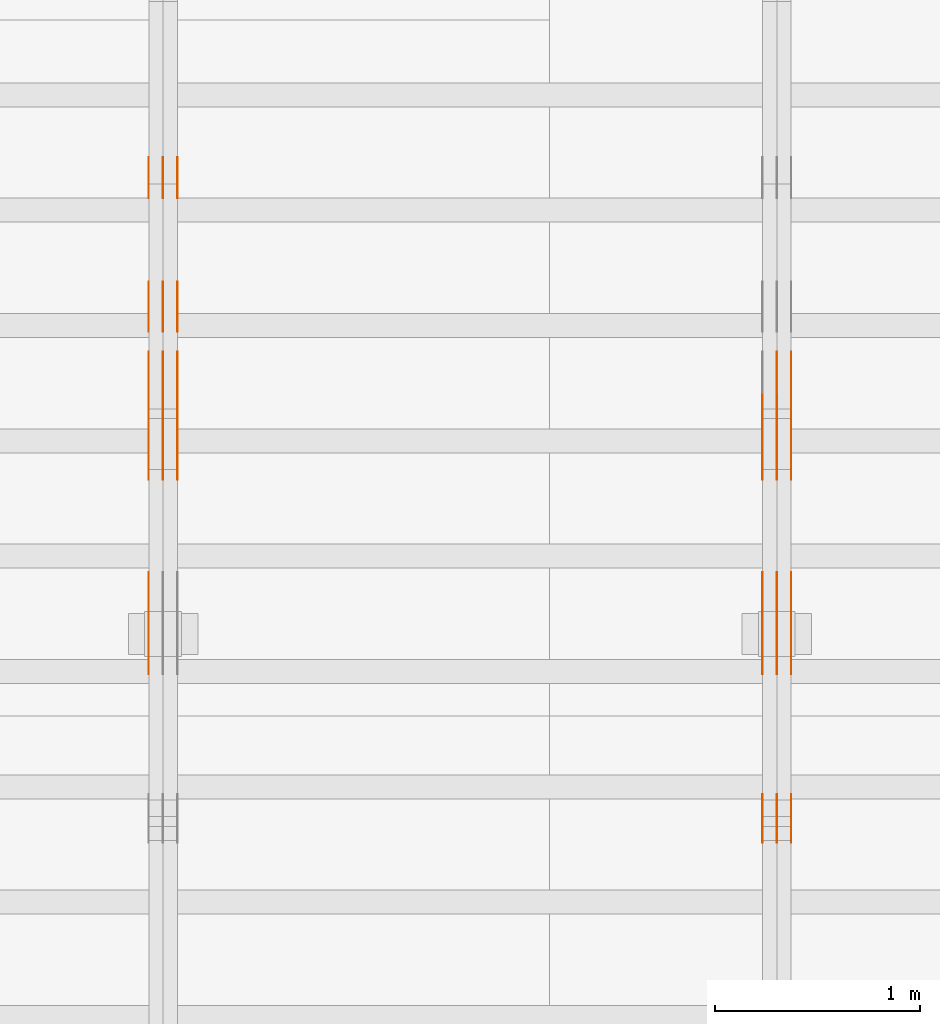
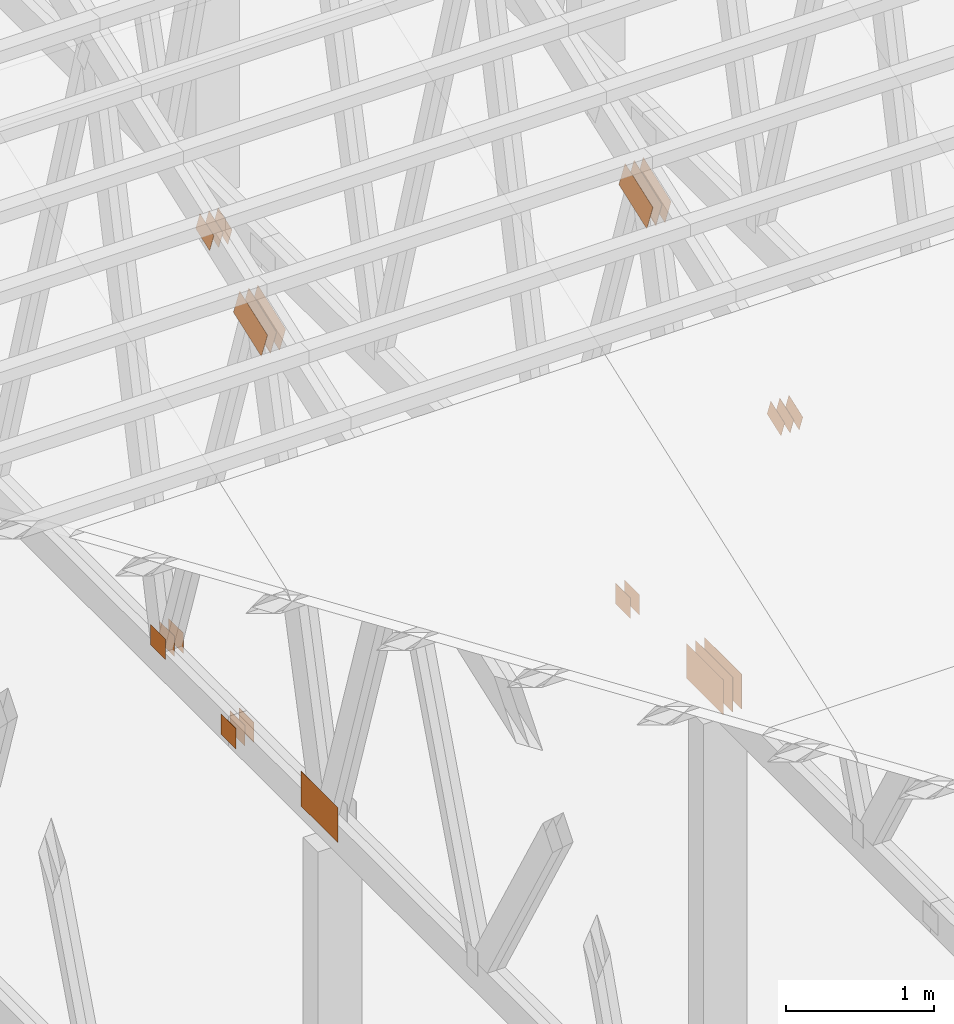
# One storey, part 77 of 189: 31 proxies.
"""IFC2X3 building model written with IfcOpenShell, lengths in millimetres."""

from ifc_helpers import new_model, entity, si_unit, converted_unit, derived_unit, direction, frame, frame_2d, origin, origin_2d_with_axis, place, context, subcontext, project, spatial, polyline, rectangle, outline, extrude, source, transform, mapped, material, type_object, type_shapes, element, save


model = new_model("IFC2X3")

# Units and contexts
model_context = context("Model", 3, precision=0.01, world=origin(), true_north=direction((6.12303176911189e-17, 1.0)))
body_context = subcontext(model_context, "Body", "Model", "MODEL_VIEW")
ifc_project = project(units=[si_unit("LENGTHUNIT", "METRE", prefix="MILLI"), si_unit("AREAUNIT", "SQUARE_METRE"), si_unit("VOLUMEUNIT", "CUBIC_METRE"), converted_unit("PLANEANGLEUNIT", "DEGREE", entity("IfcRatioMeasure", 0.0174532925199433), si_unit("PLANEANGLEUNIT", "RADIAN"), dimensions=[0, 0, 0, 0, 0, 0, 0]), si_unit("MASSUNIT", "GRAM", prefix="KILO"), derived_unit("MASSDENSITYUNIT", [(si_unit("MASSUNIT", "GRAM", prefix="KILO"), 1), (si_unit("LENGTHUNIT", "METRE"), -3)]), si_unit("TIMEUNIT", "SECOND"), si_unit("FREQUENCYUNIT", "HERTZ"), si_unit("THERMODYNAMICTEMPERATUREUNIT", "DEGREE_CELSIUS"), derived_unit("THERMALTRANSMITTANCEUNIT", [(si_unit("MASSUNIT", "GRAM", prefix="KILO"), 1), (si_unit("THERMODYNAMICTEMPERATUREUNIT", "KELVIN"), -1), (si_unit("TIMEUNIT", "SECOND"), -3)]), derived_unit("VOLUMETRICFLOWRATEUNIT", [(si_unit("LENGTHUNIT", "METRE"), 3), (si_unit("TIMEUNIT", "SECOND"), -1)]), si_unit("ELECTRICCURRENTUNIT", "AMPERE"), si_unit("ELECTRICVOLTAGEUNIT", "VOLT"), si_unit("POWERUNIT", "WATT"), si_unit("FORCEUNIT", "NEWTON"), si_unit("ILLUMINANCEUNIT", "LUX"), si_unit("LUMINOUSFLUXUNIT", "LUMEN"), si_unit("LUMINOUSINTENSITYUNIT", "CANDELA"), derived_unit("USERDEFINED", [(si_unit("MASSUNIT", "GRAM", prefix="KILO"), -1), (si_unit("LENGTHUNIT", "METRE"), -2), (si_unit("TIMEUNIT", "SECOND"), 3), (si_unit("LUMINOUSFLUXUNIT", "LUMEN"), 1)]), derived_unit("LINEARVELOCITYUNIT", [(si_unit("LENGTHUNIT", "METRE"), 1), (si_unit("TIMEUNIT", "SECOND"), -1)]), si_unit("PRESSUREUNIT", "PASCAL"), derived_unit("USERDEFINED", [(si_unit("LENGTHUNIT", "METRE"), -2), (si_unit("MASSUNIT", "GRAM", prefix="KILO"), 1), (si_unit("TIMEUNIT", "SECOND"), -2)])], contexts=[model_context])

# Site, building, storey
site_placement = place(None, origin())
site = spatial("IfcSite", under=ifc_project, at=site_placement, CompositionType="ELEMENT")
building_placement = place(site_placement, origin())
building = spatial("IfcBuilding", under=site, at=building_placement, CompositionType="ELEMENT")
storey_placement = place(building_placement, origin())
storey = spatial("IfcBuildingStorey", under=building, at=storey_placement, Name="Default", CompositionType="ELEMENT", Elevation=0.0)

# Proxies
ifc_material_1 = material(Name="IfcSurfaceStyle #45142")
building_element_proxy_type_1 = type_object("IfcBuildingElementProxyType", PredefinedType="NOTDEFINED", material=ifc_material_1)
shared_shape_1 = source(origin(), body_context, "Body", "SweptSolid", [
    extrude(outline(polyline([(-199.999582244654, -119.99984375717), (200.000344770932, -119.99984375717), (199.999582244655, 119.99984375717), (-200.000344770934, 119.99984375717), (-199.999582244654, -119.99984375717)])), frame((200.000344770932, 120.0000091947, 0.0), z_axis=(0.0, 0.0, 1.0), x_axis=(-1.0, 0.0, 0.0)), (0.0, 0.0, 1.0), 1.29999999999999),
])
type_shapes(building_element_proxy_type_1, [shared_shape_1])
proxy_1_placement = place(building_placement, frame((6336.3, 9961.90704972973, 3612.2451494258), z_axis=(-1.0, 0.0, 0.0), x_axis=(0.0, -0.939692620785908, -0.342020143325669)))
element("IfcBuildingElementProxy", 1, at=proxy_1_placement, inside=storey, type_object=building_element_proxy_type_1, material=ifc_material_1, context=body_context, shape_type="MappedRepresentation", body=[
    mapped(shared_shape_1, transform((0.0, 0.0, 0.0), scale=1.0)),
])
ifc_material_2 = material(Name="IfcSurfaceStyle #45085")
building_element_proxy_type_2 = type_object("IfcBuildingElementProxyType", PredefinedType="NOTDEFINED", material=ifc_material_2)
shared_shape_2 = source(origin(), body_context, "Body", "SweptSolid", [
    extrude(outline(polyline([(-199.999582244654, -119.99984375717), (200.000344770932, -119.99984375717), (199.999582244655, 119.99984375717), (-200.000344770934, 119.99984375717), (-199.999582244654, -119.99984375717)])), frame((200.000344770932, 120.0000091947, 0.0), z_axis=(0.0, 0.0, 1.0), x_axis=(-1.0, 0.0, 0.0)), (0.0, 0.0, 1.0), 1.29999999999997),
])
type_shapes(building_element_proxy_type_2, [shared_shape_2])
proxy_2_placement = place(building_placement, frame((6265.0, 9961.90704972973, 3612.2451494258), z_axis=(-1.0, 0.0, 0.0), x_axis=(0.0, -0.939692620785908, -0.342020143325669)))
element("IfcBuildingElementProxy", 2, at=proxy_2_placement, inside=storey, type_object=building_element_proxy_type_2, material=ifc_material_2, context=body_context, shape_type="MappedRepresentation", body=[
    mapped(shared_shape_2, transform((0.0, 0.0, 0.0), scale=1.0)),
])
ifc_material_3 = material(Name="IfcSurfaceStyle #45028")
building_element_proxy_type_3 = type_object("IfcBuildingElementProxyType", PredefinedType="NOTDEFINED", material=ifc_material_3)
shared_shape_3 = source(origin(), body_context, "Body", "SweptSolid", [
    extrude(outline(polyline([(-199.999582244654, -119.99984375717), (200.000344770932, -119.99984375717), (199.999582244655, 119.99984375717), (-200.000344770934, 119.99984375717), (-199.999582244654, -119.99984375717)])), frame((200.000344770932, 120.0000091947, 0.0), z_axis=(0.0, 0.0, 1.0), x_axis=(-1.0, 0.0, 0.0)), (0.0, 0.0, 1.0), 1.29999999999997),
])
type_shapes(building_element_proxy_type_3, [shared_shape_3])
proxy_3_placement = place(building_placement, frame((6266.3, 9961.90704972973, 3612.2451494258), z_axis=(-1.0, 0.0, 0.0), x_axis=(0.0, -0.939692620785908, -0.342020143325669)))
element("IfcBuildingElementProxy", 3, at=proxy_3_placement, inside=storey, type_object=building_element_proxy_type_3, material=ifc_material_3, context=body_context, shape_type="MappedRepresentation", body=[
    mapped(shared_shape_3, transform((0.0, 0.0, 0.0), scale=1.0)),
])
ifc_material_4 = material(Name="IfcSurfaceStyle #44971")
building_element_proxy_type_4 = type_object("IfcBuildingElementProxyType", PredefinedType="NOTDEFINED", material=ifc_material_4)
shared_shape_4 = source(origin(), body_context, "Body", "SweptSolid", [
    extrude(outline(polyline([(-199.999582244654, -119.99984375717), (200.000344770932, -119.99984375717), (199.999582244655, 119.99984375717), (-200.000344770934, 119.99984375717), (-199.999582244654, -119.99984375717)])), frame((200.000344770932, 120.0000091947, 0.0), z_axis=(0.0, 0.0, 1.0), x_axis=(-1.0, 0.0, 0.0)), (0.0, 0.0, 1.0), 1.29999999999998),
])
type_shapes(building_element_proxy_type_4, [shared_shape_4])
proxy_4_placement = place(building_placement, frame((6195.0, 9961.90704972973, 3612.2451494258), z_axis=(-1.0, 0.0, 0.0), x_axis=(0.0, -0.939692620785908, -0.342020143325669)))
element("IfcBuildingElementProxy", 4, at=proxy_4_placement, inside=storey, type_object=building_element_proxy_type_4, material=ifc_material_4, context=body_context, shape_type="MappedRepresentation", body=[
    mapped(shared_shape_4, transform((0.0, 0.0, 0.0), scale=1.0)),
])
ifc_material_5 = material(Name="IfcSurfaceStyle #44458")
building_element_proxy_type_5 = type_object("IfcBuildingElementProxyType", PredefinedType="NOTDEFINED", material=ifc_material_5)
shared_shape_5 = source(origin(), body_context, "Body", "SweptSolid", [
    extrude(rectangle(XDim=500.0, YDim=288.0, at=frame_2d((0.0, 1.4210854715202e-14), x_axis=(1.0, 0.0))), frame((250.000973740011, 144.0, 0.0), z_axis=(0.0, 0.0, 1.0), x_axis=(-1.0, 0.0, 0.0)), (0.0, 0.0, 1.0), 1.29999999999998),
])
type_shapes(building_element_proxy_type_5, [shared_shape_5])
proxy_5_placement = place(building_placement, frame((6336.3, 8551.90918250999, 389.0), z_axis=(-1.0, 0.0, 0.0), x_axis=(0.0, 1.0, 0.0)))
element("IfcBuildingElementProxy", 5, at=proxy_5_placement, inside=storey, type_object=building_element_proxy_type_5, material=ifc_material_5, context=body_context, shape_type="MappedRepresentation", body=[
    mapped(shared_shape_5, transform((0.0, 0.0, 0.0), scale=1.0)),
])
ifc_material_6 = material(Name="IfcSurfaceStyle #44401")
building_element_proxy_type_6 = type_object("IfcBuildingElementProxyType", PredefinedType="NOTDEFINED", material=ifc_material_6)
shared_shape_6 = source(origin(), body_context, "Body", "SweptSolid", [
    extrude(rectangle(XDim=500.0, YDim=288.0, at=frame_2d((0.0, 1.4210854715202e-14), x_axis=(1.0, 0.0))), frame((250.000973740011, 144.0, 0.0), z_axis=(0.0, 0.0, 1.0), x_axis=(-1.0, 0.0, 0.0)), (0.0, 0.0, 1.0), 1.29999999999997),
])
type_shapes(building_element_proxy_type_6, [shared_shape_6])
proxy_6_placement = place(building_placement, frame((6265.0, 8551.90918250999, 389.0), z_axis=(-1.0, 0.0, 0.0), x_axis=(0.0, 1.0, 0.0)))
element("IfcBuildingElementProxy", 6, at=proxy_6_placement, inside=storey, type_object=building_element_proxy_type_6, material=ifc_material_6, context=body_context, shape_type="MappedRepresentation", body=[
    mapped(shared_shape_6, transform((0.0, 0.0, 0.0), scale=1.0)),
])
ifc_material_7 = material(Name="IfcSurfaceStyle #44344")
building_element_proxy_type_7 = type_object("IfcBuildingElementProxyType", PredefinedType="NOTDEFINED", material=ifc_material_7)
shared_shape_7 = source(origin(), body_context, "Body", "SweptSolid", [
    extrude(rectangle(XDim=500.0, YDim=288.0, at=frame_2d((0.0, 1.4210854715202e-14), x_axis=(1.0, 0.0))), frame((250.000973740011, 144.0, 0.0), z_axis=(0.0, 0.0, 1.0), x_axis=(-1.0, 0.0, 0.0)), (0.0, 0.0, 1.0), 1.29999999999997),
])
type_shapes(building_element_proxy_type_7, [shared_shape_7])
proxy_7_placement = place(building_placement, frame((6266.3, 8551.90918250999, 389.0), z_axis=(-1.0, 0.0, 0.0), x_axis=(0.0, 1.0, 0.0)))
element("IfcBuildingElementProxy", 7, at=proxy_7_placement, inside=storey, type_object=building_element_proxy_type_7, material=ifc_material_7, context=body_context, shape_type="MappedRepresentation", body=[
    mapped(shared_shape_7, transform((0.0, 0.0, 0.0), scale=1.0)),
])
ifc_material_8 = material(Name="IfcSurfaceStyle #44287")
building_element_proxy_type_8 = type_object("IfcBuildingElementProxyType", PredefinedType="NOTDEFINED", material=ifc_material_8)
shared_shape_8 = source(origin(), body_context, "Body", "SweptSolid", [
    extrude(rectangle(XDim=500.0, YDim=288.0, at=frame_2d((0.0, 1.4210854715202e-14), x_axis=(1.0, 0.0))), frame((250.000973740011, 144.0, 0.0), z_axis=(0.0, 0.0, 1.0), x_axis=(-1.0, 0.0, 0.0)), (0.0, 0.0, 1.0), 1.29999999999997),
])
type_shapes(building_element_proxy_type_8, [shared_shape_8])
proxy_8_placement = place(building_placement, frame((6195.0, 8551.90918250999, 389.0), z_axis=(-1.0, 0.0, 0.0), x_axis=(0.0, 1.0, 0.0)))
element("IfcBuildingElementProxy", 8, at=proxy_8_placement, inside=storey, type_object=building_element_proxy_type_8, material=ifc_material_8, context=body_context, shape_type="MappedRepresentation", body=[
    mapped(shared_shape_8, transform((0.0, 0.0, 0.0), scale=1.0)),
])
ifc_material_9 = material(Name="IfcSurfaceStyle #44230")
building_element_proxy_type_9 = type_object("IfcBuildingElementProxyType", PredefinedType="NOTDEFINED", material=ifc_material_9)
shared_shape_9 = source(origin(), body_context, "Body", "SweptSolid", [
    extrude(outline(polyline([(-100.00048713087, -72.0000025659129), (100.000394045495, -72.0000025659129), (99.9995694622958, 72.0000025659129), (-99.9994763769209, 72.0000025659128), (-100.00048713087, -72.0000025659129)])), frame((100.000394045495, 72.0000025659128, 0.0), z_axis=(0.0, 0.0, 1.0), x_axis=(-1.0, 0.0, 0.0)), (0.0, 0.0, 1.0), 1.3),
])
type_shapes(building_element_proxy_type_9, [shared_shape_9])
proxy_9_placement = place(building_placement, frame((6336.3, 7965.16887114408, 2936.19963864386), z_axis=(-1.0, 0.0, 0.0), x_axis=(0.0, -0.939692620785908, -0.342020143325669)))
element("IfcBuildingElementProxy", 9, at=proxy_9_placement, inside=storey, type_object=building_element_proxy_type_9, material=ifc_material_9, context=body_context, shape_type="MappedRepresentation", body=[
    mapped(shared_shape_9, transform((0.0, 0.0, 0.0), scale=1.0)),
])
ifc_material_10 = material(Name="IfcSurfaceStyle #44173")
building_element_proxy_type_10 = type_object("IfcBuildingElementProxyType", PredefinedType="NOTDEFINED", material=ifc_material_10)
shared_shape_10 = source(origin(), body_context, "Body", "SweptSolid", [
    extrude(outline(polyline([(-100.00048713087, -72.0000025659129), (100.000394045495, -72.0000025659129), (99.9995694622958, 72.0000025659129), (-99.9994763769209, 72.0000025659128), (-100.00048713087, -72.0000025659129)])), frame((100.000394045495, 72.0000025659128, 0.0), z_axis=(0.0, 0.0, 1.0), x_axis=(-1.0, 0.0, 0.0)), (0.0, 0.0, 1.0), 1.29999999999998),
])
type_shapes(building_element_proxy_type_10, [shared_shape_10])
proxy_10_placement = place(building_placement, frame((6265.0, 7965.16887114408, 2936.19963864386), z_axis=(-1.0, 0.0, 0.0), x_axis=(0.0, -0.939692620785908, -0.342020143325669)))
element("IfcBuildingElementProxy", 10, at=proxy_10_placement, inside=storey, type_object=building_element_proxy_type_10, material=ifc_material_10, context=body_context, shape_type="MappedRepresentation", body=[
    mapped(shared_shape_10, transform((0.0, 0.0, 0.0), scale=1.0)),
])
ifc_material_11 = material(Name="IfcSurfaceStyle #44116")
building_element_proxy_type_11 = type_object("IfcBuildingElementProxyType", PredefinedType="NOTDEFINED", material=ifc_material_11)
shared_shape_11 = source(origin(), body_context, "Body", "SweptSolid", [
    extrude(outline(polyline([(-100.00048713087, -72.0000025659129), (100.000394045495, -72.0000025659129), (99.9995694622958, 72.0000025659129), (-99.9994763769209, 72.0000025659128), (-100.00048713087, -72.0000025659129)])), frame((100.000394045495, 72.0000025659128, 0.0), z_axis=(0.0, 0.0, 1.0), x_axis=(-1.0, 0.0, 0.0)), (0.0, 0.0, 1.0), 1.29999999999998),
])
type_shapes(building_element_proxy_type_11, [shared_shape_11])
proxy_11_placement = place(building_placement, frame((6266.3, 7965.16887114408, 2936.19963864386), z_axis=(-1.0, 0.0, 0.0), x_axis=(0.0, -0.939692620785908, -0.342020143325669)))
element("IfcBuildingElementProxy", 11, at=proxy_11_placement, inside=storey, type_object=building_element_proxy_type_11, material=ifc_material_11, context=body_context, shape_type="MappedRepresentation", body=[
    mapped(shared_shape_11, transform((0.0, 0.0, 0.0), scale=1.0)),
])
ifc_material_12 = material(Name="IfcSurfaceStyle #44059")
building_element_proxy_type_12 = type_object("IfcBuildingElementProxyType", PredefinedType="NOTDEFINED", material=ifc_material_12)
shared_shape_12 = source(origin(), body_context, "Body", "SweptSolid", [
    extrude(outline(polyline([(-100.00048713087, -72.0000025659129), (100.000394045495, -72.0000025659129), (99.9995694622958, 72.0000025659129), (-99.9994763769209, 72.0000025659128), (-100.00048713087, -72.0000025659129)])), frame((100.000394045495, 72.0000025659128, 0.0), z_axis=(0.0, 0.0, 1.0), x_axis=(-1.0, 0.0, 0.0)), (0.0, 0.0, 1.0), 1.29999999999999),
])
type_shapes(building_element_proxy_type_12, [shared_shape_12])
proxy_12_placement = place(building_placement, frame((6195.0, 7965.16887114408, 2936.19963864386), z_axis=(-1.0, 0.0, 0.0), x_axis=(0.0, -0.939692620785908, -0.342020143325669)))
element("IfcBuildingElementProxy", 12, at=proxy_12_placement, inside=storey, type_object=building_element_proxy_type_12, material=ifc_material_12, context=body_context, shape_type="MappedRepresentation", body=[
    mapped(shared_shape_12, transform((0.0, 0.0, 0.0), scale=1.0)),
])
ifc_material_13 = material(Name="IfcSurfaceStyle #38818")
building_element_proxy_type_13 = type_object("IfcBuildingElementProxyType", PredefinedType="NOTDEFINED", material=ifc_material_13)
shared_shape_13 = source(origin(), body_context, "Body", "SweptSolid", [
    extrude(rectangle(XDim=200.0, YDim=168.0, at=origin_2d_with_axis()), frame((100.0, 84.0, 0.0), z_axis=(0.0, 0.0, 1.0), x_axis=(-1.0, 0.0, 0.0)), (0.0, 0.0, 1.0), 1.3),
])
type_shapes(building_element_proxy_type_13, [shared_shape_13])
proxy_13_placement = place(building_placement, frame((6336.3, 9929.23046875, 206.5), z_axis=(-1.0, 0.0, 0.0), x_axis=(0.0, 1.0, 0.0)))
element("IfcBuildingElementProxy", 13, at=proxy_13_placement, inside=storey, type_object=building_element_proxy_type_13, material=ifc_material_13, context=body_context, shape_type="MappedRepresentation", body=[
    mapped(shared_shape_13, transform((0.0, 0.0, 0.0), scale=1.0)),
])
ifc_material_14 = material(Name="IfcSurfaceStyle #38761")
building_element_proxy_type_14 = type_object("IfcBuildingElementProxyType", PredefinedType="NOTDEFINED", material=ifc_material_14)
shared_shape_14 = source(origin(), body_context, "Body", "SweptSolid", [
    extrude(rectangle(XDim=200.0, YDim=168.0, at=origin_2d_with_axis()), frame((100.0, 84.0, 0.0), z_axis=(0.0, 0.0, 1.0), x_axis=(-1.0, 0.0, 0.0)), (0.0, 0.0, 1.0), 1.29999999999998),
])
type_shapes(building_element_proxy_type_14, [shared_shape_14])
proxy_14_placement = place(building_placement, frame((6265.0, 9929.23046875, 206.5), z_axis=(-1.0, 0.0, 0.0), x_axis=(0.0, 1.0, 0.0)))
element("IfcBuildingElementProxy", 14, at=proxy_14_placement, inside=storey, type_object=building_element_proxy_type_14, material=ifc_material_14, context=body_context, shape_type="MappedRepresentation", body=[
    mapped(shared_shape_14, transform((0.0, 0.0, 0.0), scale=1.0)),
])
ifc_material_15 = material(Name="IfcSurfaceStyle #29580")
building_element_proxy_type_15 = type_object("IfcBuildingElementProxyType", PredefinedType="NOTDEFINED", material=ifc_material_15)
shared_shape_15 = source(origin(), body_context, "Body", "SweptSolid", [
    extrude(rectangle(XDim=200.0, YDim=168.0, at=origin_2d_with_axis()), frame((100.000765376775, 84.0, 0.0), z_axis=(0.0, 0.0, 1.0), x_axis=(-1.0, 0.0, 0.0)), (0.0, 0.0, 1.0), 1.3),
])
type_shapes(building_element_proxy_type_15, [shared_shape_15])
proxy_15_placement = place(building_placement, frame((3336.3, 10880.1574377482, 365.0), z_axis=(-1.0, 0.0, 0.0), x_axis=(0.0, 1.0, 0.0)))
element("IfcBuildingElementProxy", 15, at=proxy_15_placement, inside=storey, type_object=building_element_proxy_type_15, material=ifc_material_15, context=body_context, shape_type="MappedRepresentation", body=[
    mapped(shared_shape_15, transform((0.0, 0.0, 0.0), scale=1.0)),
])
ifc_material_16 = material(Name="IfcSurfaceStyle #29523")
building_element_proxy_type_16 = type_object("IfcBuildingElementProxyType", PredefinedType="NOTDEFINED", material=ifc_material_16)
shared_shape_16 = source(origin(), body_context, "Body", "SweptSolid", [
    extrude(rectangle(XDim=200.0, YDim=168.0, at=origin_2d_with_axis()), frame((100.000765376775, 84.0, 0.0), z_axis=(0.0, 0.0, 1.0), x_axis=(-1.0, 0.0, 0.0)), (0.0, 0.0, 1.0), 1.29999999999998),
])
type_shapes(building_element_proxy_type_16, [shared_shape_16])
proxy_16_placement = place(building_placement, frame((3265.0, 10880.1574377482, 365.0), z_axis=(-1.0, 0.0, 0.0), x_axis=(0.0, 1.0, 0.0)))
element("IfcBuildingElementProxy", 16, at=proxy_16_placement, inside=storey, type_object=building_element_proxy_type_16, material=ifc_material_16, context=body_context, shape_type="MappedRepresentation", body=[
    mapped(shared_shape_16, transform((0.0, 0.0, 0.0), scale=1.0)),
])
ifc_material_17 = material(Name="IfcSurfaceStyle #29466")
building_element_proxy_type_17 = type_object("IfcBuildingElementProxyType", PredefinedType="NOTDEFINED", material=ifc_material_17)
shared_shape_17 = source(origin(), body_context, "Body", "SweptSolid", [
    extrude(rectangle(XDim=200.0, YDim=168.0, at=origin_2d_with_axis()), frame((100.000765376775, 84.0, 0.0), z_axis=(0.0, 0.0, 1.0), x_axis=(-1.0, 0.0, 0.0)), (0.0, 0.0, 1.0), 1.29999999999998),
])
type_shapes(building_element_proxy_type_17, [shared_shape_17])
proxy_17_placement = place(building_placement, frame((3266.3, 10880.1574377482, 365.0), z_axis=(-1.0, 0.0, 0.0), x_axis=(0.0, 1.0, 0.0)))
element("IfcBuildingElementProxy", 17, at=proxy_17_placement, inside=storey, type_object=building_element_proxy_type_17, material=ifc_material_17, context=body_context, shape_type="MappedRepresentation", body=[
    mapped(shared_shape_17, transform((0.0, 0.0, 0.0), scale=1.0)),
])
ifc_material_18 = material(Name="IfcSurfaceStyle #29409")
building_element_proxy_type_18 = type_object("IfcBuildingElementProxyType", PredefinedType="NOTDEFINED", material=ifc_material_18)
shared_shape_18 = source(origin(), body_context, "Body", "SweptSolid", [
    extrude(rectangle(XDim=200.0, YDim=168.0, at=origin_2d_with_axis()), frame((100.000765376775, 84.0, 0.0), z_axis=(0.0, 0.0, 1.0), x_axis=(-1.0, 0.0, 0.0)), (0.0, 0.0, 1.0), 1.29999999999999),
])
type_shapes(building_element_proxy_type_18, [shared_shape_18])
proxy_18_placement = place(building_placement, frame((3195.0, 10880.1574377482, 365.0), z_axis=(-1.0, 0.0, 0.0), x_axis=(0.0, 1.0, 0.0)))
element("IfcBuildingElementProxy", 18, at=proxy_18_placement, inside=storey, type_object=building_element_proxy_type_18, material=ifc_material_18, context=body_context, shape_type="MappedRepresentation", body=[
    mapped(shared_shape_18, transform((0.0, 0.0, 0.0), scale=1.0)),
])
ifc_material_19 = material(Name="IfcSurfaceStyle #29352")
building_element_proxy_type_19 = type_object("IfcBuildingElementProxyType", PredefinedType="NOTDEFINED", material=ifc_material_19)
shared_shape_19 = source(origin(), body_context, "Body", "SweptSolid", [
    extrude(outline(polyline([(-199.999582244654, -119.99984375717), (200.000344770932, -119.99984375717), (199.999582244655, 119.99984375717), (-200.000344770934, 119.99984375717), (-199.999582244654, -119.99984375717)])), frame((200.000344770932, 120.0000091947, 0.0), z_axis=(0.0, 0.0, 1.0), x_axis=(-1.0, 0.0, 0.0)), (0.0, 0.0, 1.0), 1.29999999999999),
])
type_shapes(building_element_proxy_type_19, [shared_shape_19])
proxy_19_placement = place(building_placement, frame((3336.3, 9961.90704972973, 3612.2451494258), z_axis=(-1.0, 0.0, 0.0), x_axis=(0.0, -0.939692620785908, -0.342020143325669)))
element("IfcBuildingElementProxy", 19, at=proxy_19_placement, inside=storey, type_object=building_element_proxy_type_19, material=ifc_material_19, context=body_context, shape_type="MappedRepresentation", body=[
    mapped(shared_shape_19, transform((0.0, 0.0, 0.0), scale=1.0)),
])
ifc_material_20 = material(Name="IfcSurfaceStyle #29295")
building_element_proxy_type_20 = type_object("IfcBuildingElementProxyType", PredefinedType="NOTDEFINED", material=ifc_material_20)
shared_shape_20 = source(origin(), body_context, "Body", "SweptSolid", [
    extrude(outline(polyline([(-199.999582244654, -119.99984375717), (200.000344770932, -119.99984375717), (199.999582244655, 119.99984375717), (-200.000344770934, 119.99984375717), (-199.999582244654, -119.99984375717)])), frame((200.000344770932, 120.0000091947, 0.0), z_axis=(0.0, 0.0, 1.0), x_axis=(-1.0, 0.0, 0.0)), (0.0, 0.0, 1.0), 1.29999999999997),
])
type_shapes(building_element_proxy_type_20, [shared_shape_20])
proxy_20_placement = place(building_placement, frame((3265.0, 9961.90704972973, 3612.2451494258), z_axis=(-1.0, 0.0, 0.0), x_axis=(0.0, -0.939692620785908, -0.342020143325669)))
element("IfcBuildingElementProxy", 20, at=proxy_20_placement, inside=storey, type_object=building_element_proxy_type_20, material=ifc_material_20, context=body_context, shape_type="MappedRepresentation", body=[
    mapped(shared_shape_20, transform((0.0, 0.0, 0.0), scale=1.0)),
])
ifc_material_21 = material(Name="IfcSurfaceStyle #29238")
building_element_proxy_type_21 = type_object("IfcBuildingElementProxyType", PredefinedType="NOTDEFINED", material=ifc_material_21)
shared_shape_21 = source(origin(), body_context, "Body", "SweptSolid", [
    extrude(outline(polyline([(-199.999582244654, -119.99984375717), (200.000344770932, -119.99984375717), (199.999582244655, 119.99984375717), (-200.000344770934, 119.99984375717), (-199.999582244654, -119.99984375717)])), frame((200.000344770932, 120.0000091947, 0.0), z_axis=(0.0, 0.0, 1.0), x_axis=(-1.0, 0.0, 0.0)), (0.0, 0.0, 1.0), 1.29999999999997),
])
type_shapes(building_element_proxy_type_21, [shared_shape_21])
proxy_21_placement = place(building_placement, frame((3266.3, 9961.90704972973, 3612.2451494258), z_axis=(-1.0, 0.0, 0.0), x_axis=(0.0, -0.939692620785908, -0.342020143325669)))
element("IfcBuildingElementProxy", 21, at=proxy_21_placement, inside=storey, type_object=building_element_proxy_type_21, material=ifc_material_21, context=body_context, shape_type="MappedRepresentation", body=[
    mapped(shared_shape_21, transform((0.0, 0.0, 0.0), scale=1.0)),
])
ifc_material_22 = material(Name="IfcSurfaceStyle #29181")
building_element_proxy_type_22 = type_object("IfcBuildingElementProxyType", PredefinedType="NOTDEFINED", material=ifc_material_22)
shared_shape_22 = source(origin(), body_context, "Body", "SweptSolid", [
    extrude(outline(polyline([(-199.999582244654, -119.99984375717), (200.000344770932, -119.99984375717), (199.999582244655, 119.99984375717), (-200.000344770934, 119.99984375717), (-199.999582244654, -119.99984375717)])), frame((200.000344770932, 120.0000091947, 0.0), z_axis=(0.0, 0.0, 1.0), x_axis=(-1.0, 0.0, 0.0)), (0.0, 0.0, 1.0), 1.29999999999998),
])
type_shapes(building_element_proxy_type_22, [shared_shape_22])
proxy_22_placement = place(building_placement, frame((3195.0, 9961.90704972973, 3612.2451494258), z_axis=(-1.0, 0.0, 0.0), x_axis=(0.0, -0.939692620785908, -0.342020143325669)))
element("IfcBuildingElementProxy", 22, at=proxy_22_placement, inside=storey, type_object=building_element_proxy_type_22, material=ifc_material_22, context=body_context, shape_type="MappedRepresentation", body=[
    mapped(shared_shape_22, transform((0.0, 0.0, 0.0), scale=1.0)),
])
ifc_material_23 = material(Name="IfcSurfaceStyle #28497")
building_element_proxy_type_23 = type_object("IfcBuildingElementProxyType", PredefinedType="NOTDEFINED", material=ifc_material_23)
shared_shape_23 = source(origin(), body_context, "Body", "SweptSolid", [
    extrude(rectangle(XDim=500.0, YDim=288.0, at=frame_2d((0.0, 1.4210854715202e-14), x_axis=(1.0, 0.0))), frame((250.000973740011, 144.0, 0.0), z_axis=(0.0, 0.0, 1.0), x_axis=(-1.0, 0.0, 0.0)), (0.0, 0.0, 1.0), 1.29999999999997),
])
type_shapes(building_element_proxy_type_23, [shared_shape_23])
proxy_23_placement = place(building_placement, frame((3195.0, 8551.90918250999, 389.0), z_axis=(-1.0, 0.0, 0.0), x_axis=(0.0, 1.0, 0.0)))
element("IfcBuildingElementProxy", 23, at=proxy_23_placement, inside=storey, type_object=building_element_proxy_type_23, material=ifc_material_23, context=body_context, shape_type="MappedRepresentation", body=[
    mapped(shared_shape_23, transform((0.0, 0.0, 0.0), scale=1.0)),
])
ifc_material_24 = material(Name="IfcSurfaceStyle #23028")
building_element_proxy_type_24 = type_object("IfcBuildingElementProxyType", PredefinedType="NOTDEFINED", material=ifc_material_24)
shared_shape_24 = source(origin(), body_context, "Body", "SweptSolid", [
    extrude(rectangle(XDim=200.0, YDim=168.0, at=origin_2d_with_axis()), frame((100.0, 84.0, 0.0), z_axis=(0.0, 0.0, 1.0), x_axis=(-1.0, 0.0, 0.0)), (0.0, 0.0, 1.0), 1.3),
])
type_shapes(building_element_proxy_type_24, [shared_shape_24])
proxy_24_placement = place(building_placement, frame((3336.3, 9929.23046875, 206.5), z_axis=(-1.0, 0.0, 0.0), x_axis=(0.0, 1.0, 0.0)))
element("IfcBuildingElementProxy", 24, at=proxy_24_placement, inside=storey, type_object=building_element_proxy_type_24, material=ifc_material_24, context=body_context, shape_type="MappedRepresentation", body=[
    mapped(shared_shape_24, transform((0.0, 0.0, 0.0), scale=1.0)),
])
ifc_material_25 = material(Name="IfcSurfaceStyle #22971")
building_element_proxy_type_25 = type_object("IfcBuildingElementProxyType", PredefinedType="NOTDEFINED", material=ifc_material_25)
shared_shape_25 = source(origin(), body_context, "Body", "SweptSolid", [
    extrude(rectangle(XDim=200.0, YDim=168.0, at=origin_2d_with_axis()), frame((100.0, 84.0, 0.0), z_axis=(0.0, 0.0, 1.0), x_axis=(-1.0, 0.0, 0.0)), (0.0, 0.0, 1.0), 1.29999999999998),
])
type_shapes(building_element_proxy_type_25, [shared_shape_25])
proxy_25_placement = place(building_placement, frame((3265.0, 9929.23046875, 206.5), z_axis=(-1.0, 0.0, 0.0), x_axis=(0.0, 1.0, 0.0)))
element("IfcBuildingElementProxy", 25, at=proxy_25_placement, inside=storey, type_object=building_element_proxy_type_25, material=ifc_material_25, context=body_context, shape_type="MappedRepresentation", body=[
    mapped(shared_shape_25, transform((0.0, 0.0, 0.0), scale=1.0)),
])
ifc_material_26 = material(Name="IfcSurfaceStyle #22914")
building_element_proxy_type_26 = type_object("IfcBuildingElementProxyType", PredefinedType="NOTDEFINED", material=ifc_material_26)
shared_shape_26 = source(origin(), body_context, "Body", "SweptSolid", [
    extrude(rectangle(XDim=200.0, YDim=168.0, at=origin_2d_with_axis()), frame((100.0, 84.0, 0.0), z_axis=(0.0, 0.0, 1.0), x_axis=(-1.0, 0.0, 0.0)), (0.0, 0.0, 1.0), 1.29999999999998),
])
type_shapes(building_element_proxy_type_26, [shared_shape_26])
proxy_26_placement = place(building_placement, frame((3266.3, 9929.23046875, 206.5), z_axis=(-1.0, 0.0, 0.0), x_axis=(0.0, 1.0, 0.0)))
element("IfcBuildingElementProxy", 26, at=proxy_26_placement, inside=storey, type_object=building_element_proxy_type_26, material=ifc_material_26, context=body_context, shape_type="MappedRepresentation", body=[
    mapped(shared_shape_26, transform((0.0, 0.0, 0.0), scale=1.0)),
])
ifc_material_27 = material(Name="IfcSurfaceStyle #22857")
building_element_proxy_type_27 = type_object("IfcBuildingElementProxyType", PredefinedType="NOTDEFINED", material=ifc_material_27)
shared_shape_27 = source(origin(), body_context, "Body", "SweptSolid", [
    extrude(rectangle(XDim=200.0, YDim=168.0, at=origin_2d_with_axis()), frame((100.0, 84.0, 0.0), z_axis=(0.0, 0.0, 1.0), x_axis=(-1.0, 0.0, 0.0)), (0.0, 0.0, 1.0), 1.29999999999999),
])
type_shapes(building_element_proxy_type_27, [shared_shape_27])
proxy_27_placement = place(building_placement, frame((3195.0, 9929.23046875, 206.5), z_axis=(-1.0, 0.0, 0.0), x_axis=(0.0, 1.0, 0.0)))
element("IfcBuildingElementProxy", 27, at=proxy_27_placement, inside=storey, type_object=building_element_proxy_type_27, material=ifc_material_27, context=body_context, shape_type="MappedRepresentation", body=[
    mapped(shared_shape_27, transform((0.0, 0.0, 0.0), scale=1.0)),
])
ifc_material_28 = material(Name="IfcSurfaceStyle #21948")
building_element_proxy_type_28 = type_object("IfcBuildingElementProxyType", PredefinedType="NOTDEFINED", material=ifc_material_28)
shared_shape_28 = source(origin(), body_context, "Body", "SweptSolid", [
    extrude(outline(polyline([(-100.00072430513, -84.0000258989549), (100.000156871239, -84.0000258989549), (99.9997648860508, 84.0000258989549), (-99.9991974521591, 84.0000258989548), (-100.00072430513, -84.0000258989549)])), frame((100.000156871239, 84.0000258989548, 0.0), z_axis=(0.0, 0.0, 1.0), x_axis=(-1.0, 0.0, 0.0)), (0.0, 0.0, 1.0), 1.3),
])
type_shapes(building_element_proxy_type_28, [shared_shape_28])
proxy_28_placement = place(building_placement, frame((3336.3, 10226.4409888304, 4081.14941482552), z_axis=(-1.0, 0.0, 0.0), x_axis=(0.0, 0.939692620785908, 0.342020143325669)))
element("IfcBuildingElementProxy", 28, at=proxy_28_placement, inside=storey, type_object=building_element_proxy_type_28, material=ifc_material_28, context=body_context, shape_type="MappedRepresentation", body=[
    mapped(shared_shape_28, transform((0.0, 0.0, 0.0), scale=1.0)),
])
ifc_material_29 = material(Name="IfcSurfaceStyle #21891")
building_element_proxy_type_29 = type_object("IfcBuildingElementProxyType", PredefinedType="NOTDEFINED", material=ifc_material_29)
shared_shape_29 = source(origin(), body_context, "Body", "SweptSolid", [
    extrude(outline(polyline([(-100.00072430513, -84.0000258989549), (100.000156871239, -84.0000258989549), (99.9997648860508, 84.0000258989549), (-99.9991974521591, 84.0000258989548), (-100.00072430513, -84.0000258989549)])), frame((100.000156871239, 84.0000258989548, 0.0), z_axis=(0.0, 0.0, 1.0), x_axis=(-1.0, 0.0, 0.0)), (0.0, 0.0, 1.0), 1.29999999999998),
])
type_shapes(building_element_proxy_type_29, [shared_shape_29])
proxy_29_placement = place(building_placement, frame((3265.0, 10226.4409888304, 4081.14941482552), z_axis=(-1.0, 0.0, 0.0), x_axis=(0.0, 0.939692620785908, 0.342020143325669)))
element("IfcBuildingElementProxy", 29, at=proxy_29_placement, inside=storey, type_object=building_element_proxy_type_29, material=ifc_material_29, context=body_context, shape_type="MappedRepresentation", body=[
    mapped(shared_shape_29, transform((0.0, 0.0, 0.0), scale=1.0)),
])
ifc_material_30 = material(Name="IfcSurfaceStyle #21834")
building_element_proxy_type_30 = type_object("IfcBuildingElementProxyType", PredefinedType="NOTDEFINED", material=ifc_material_30)
shared_shape_30 = source(origin(), body_context, "Body", "SweptSolid", [
    extrude(outline(polyline([(-100.00072430513, -84.0000258989549), (100.000156871239, -84.0000258989549), (99.9997648860508, 84.0000258989549), (-99.9991974521591, 84.0000258989548), (-100.00072430513, -84.0000258989549)])), frame((100.000156871239, 84.0000258989548, 0.0), z_axis=(0.0, 0.0, 1.0), x_axis=(-1.0, 0.0, 0.0)), (0.0, 0.0, 1.0), 1.29999999999998),
])
type_shapes(building_element_proxy_type_30, [shared_shape_30])
proxy_30_placement = place(building_placement, frame((3266.3, 10226.4409888304, 4081.14941482552), z_axis=(-1.0, 0.0, 0.0), x_axis=(0.0, 0.939692620785908, 0.342020143325669)))
element("IfcBuildingElementProxy", 30, at=proxy_30_placement, inside=storey, type_object=building_element_proxy_type_30, material=ifc_material_30, context=body_context, shape_type="MappedRepresentation", body=[
    mapped(shared_shape_30, transform((0.0, 0.0, 0.0), scale=1.0)),
])
ifc_material_31 = material(Name="IfcSurfaceStyle #21777")
building_element_proxy_type_31 = type_object("IfcBuildingElementProxyType", PredefinedType="NOTDEFINED", material=ifc_material_31)
shared_shape_31 = source(origin(), body_context, "Body", "SweptSolid", [
    extrude(outline(polyline([(-100.00072430513, -84.0000258989549), (100.000156871239, -84.0000258989549), (99.9997648860508, 84.0000258989549), (-99.9991974521591, 84.0000258989548), (-100.00072430513, -84.0000258989549)])), frame((100.000156871239, 84.0000258989548, 0.0), z_axis=(0.0, 0.0, 1.0), x_axis=(-1.0, 0.0, 0.0)), (0.0, 0.0, 1.0), 1.29999999999999),
])
type_shapes(building_element_proxy_type_31, [shared_shape_31])
proxy_31_placement = place(building_placement, frame((3195.0, 10226.4409888304, 4081.14941482552), z_axis=(-1.0, 0.0, 0.0), x_axis=(0.0, 0.939692620785908, 0.342020143325669)))
element("IfcBuildingElementProxy", 31, at=proxy_31_placement, inside=storey, type_object=building_element_proxy_type_31, material=ifc_material_31, context=body_context, shape_type="MappedRepresentation", body=[
    mapped(shared_shape_31, transform((0.0, 0.0, 0.0), scale=1.0)),
])

save(model, "model.ifc")
